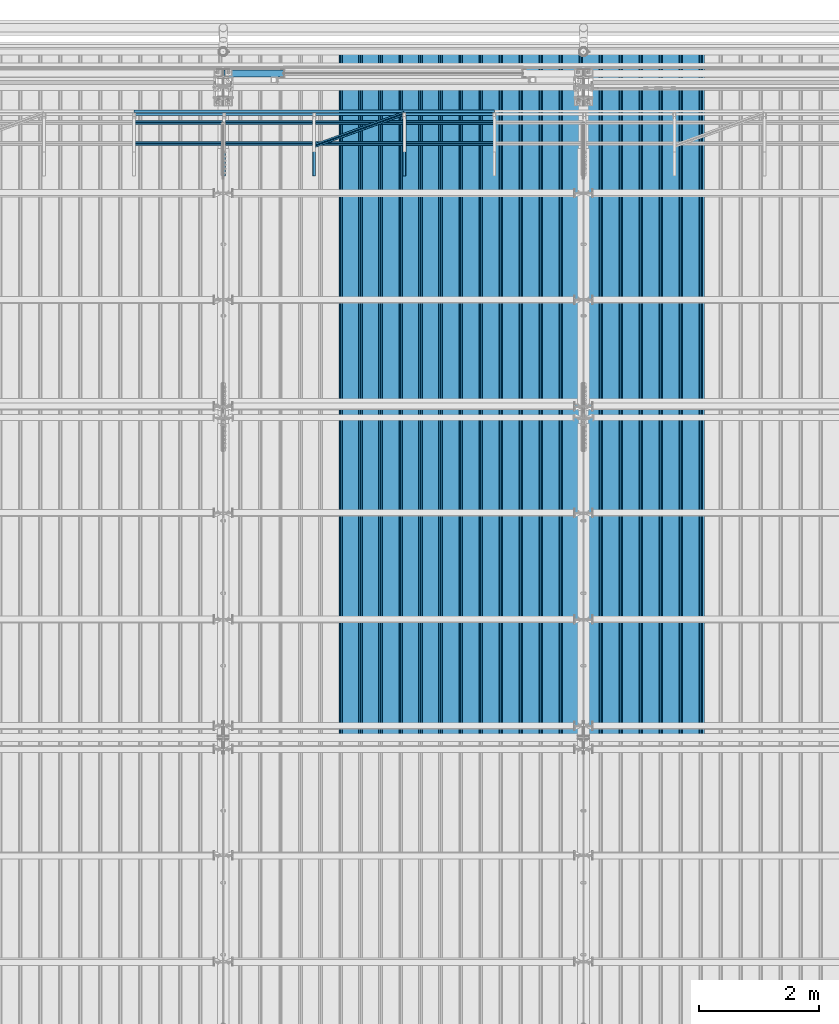
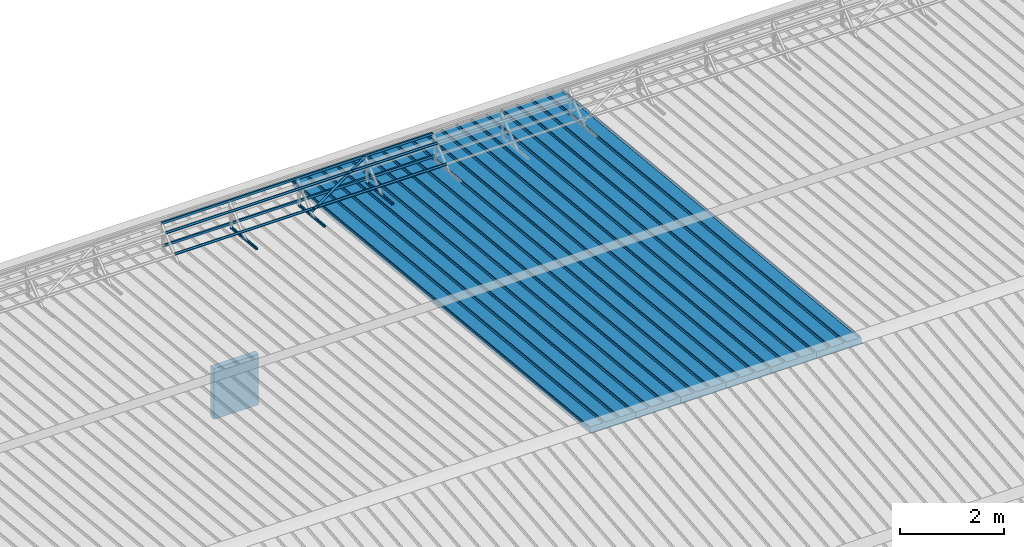
# One storey, part 57 of 709: 15 beams, 15 elements without a shape of their own.
"""IFC4 building model written with IfcOpenShell, lengths in millimetres."""

from ifc_helpers import new_model, si_unit, direction, frame, origin_with_axes, place, context, subcontext, project, spatial, line, indexed_curve, outline, extrude, material, element, aggregate, save


model = new_model("IFC4")

# Units and contexts
model_context = context("Model", 3, precision=0.2, world=origin_with_axes(), true_north=direction((0.0, 1.0)))
body_context = subcontext(model_context, "Body", "Model", "MODEL_VIEW")
ifc_project = project(units=[si_unit("LENGTHUNIT", "METRE", prefix="MILLI"), si_unit("AREAUNIT", "SQUARE_METRE"), si_unit("VOLUMEUNIT", "CUBIC_METRE"), si_unit("MASSUNIT", "GRAM", prefix="KILO"), si_unit("TIMEUNIT", "SECOND"), si_unit("PLANEANGLEUNIT", "RADIAN"), si_unit("SOLIDANGLEUNIT", "STERADIAN"), si_unit("THERMODYNAMICTEMPERATUREUNIT", "DEGREE_CELSIUS"), si_unit("LUMINOUSINTENSITYUNIT", "LUMEN")], contexts=[model_context])

# Site, building, storey
site_placement = place(None, origin_with_axes())
site = spatial("IfcSite", under=ifc_project, at=site_placement, CompositionType="ELEMENT")
building_placement = place(site_placement, origin_with_axes())
building = spatial("IfcBuilding", under=site, at=building_placement, Name="Undefined", CompositionType="ELEMENT")
storey_placement = place(building_placement, origin_with_axes())
storey = spatial("IfcBuildingStorey", under=building, at=storey_placement, Name="Undefined", CompositionType="ELEMENT", Elevation=0.0)

# Assembly, beam
assembly_1_placement = place(storey_placement, frame((23452.44, 11009.10459, 8419.96887), z_axis=(1.0, 0.0, 0.0), x_axis=(0.0, 0.9950371902, -0.099503719)))
assembly_1 = element("IfcElementAssembly", 1, at=assembly_1_placement, inside=storey)
ifc_material_1 = material(Name="Insulation", Category="Insulation")
beam_1_placement = place(assembly_1_placement, origin_with_axes())
beam_1 = element("IfcBeam", 2, at=beam_1_placement, material=ifc_material_1, ObjectType="P-99", context=body_context, shape_type="SolidModel", body=[
    extrude(outline(indexed_curve([(-509.8453, 89.5), (-490.1547, 89.5), (-471.67949, 57.5), (-471.67949, -88.5), (-436.67949, -88.5), (-436.67949, -91.5), (562.55841, -91.5), (562.55841, -89.5), (527.55841, -89.5), (527.55841, 57.5), (510.2379, 88.5), (489.7621, 88.5), (472.44159, 58.5), (196.71923, 58.5), (177.66667, 91.5), (155.66667, 91.5), (136.61411, 58.5), (-136.61411, 58.5), (-155.66667, 91.5), (-177.66667, 91.5), (-196.71923, 58.5), (-469.94744, 58.5), (-489.0, 91.5), (-511.0, 91.5), (-527.16581, 63.5), (-525.43376, 62.5)], segments=[line(1, 2, 3, 4, 5, 6, 7, 8, 9, 10, 11, 12, 13, 14, 15, 16, 17, 18, 19, 20, 21, 22, 23, 24, 25, 26, 1)])), frame((0.0, 0.0, 0.0), z_axis=(-1.0, 0.0, 0.0), x_axis=(0.0, 0.0, 1.0)), (0.0, 0.0, -1.0), 11459.0),
])
aggregate(assembly_1, [beam_1])

assembly_2_placement = place(storey_placement, frame((22452.44, 11009.10459, 8419.96887), z_axis=(1.0, 0.0, 0.0), x_axis=(0.0, 0.9950371902, -0.099503719)))
assembly_2 = element("IfcElementAssembly", 3, at=assembly_2_placement, inside=storey)
beam_2_placement = place(assembly_2_placement, origin_with_axes())
beam_2 = element("IfcBeam", 4, at=beam_2_placement, material=ifc_material_1, ObjectType="P-99", context=body_context, shape_type="SolidModel", body=[
    extrude(outline(indexed_curve([(-509.8453, 89.5), (-490.1547, 89.5), (-471.67949, 57.5), (-471.67949, -88.5), (-436.67949, -88.5), (-436.67949, -91.5), (562.55841, -91.5), (562.55841, -89.5), (527.55841, -89.5), (527.55841, 57.5), (510.2379, 88.5), (489.7621, 88.5), (472.44159, 58.5), (196.71923, 58.5), (177.66667, 91.5), (155.66667, 91.5), (136.61411, 58.5), (-136.61411, 58.5), (-155.66667, 91.5), (-177.66667, 91.5), (-196.71923, 58.5), (-469.94744, 58.5), (-489.0, 91.5), (-511.0, 91.5), (-527.16581, 63.5), (-525.43376, 62.5)], segments=[line(1, 2, 3, 4, 5, 6, 7, 8, 9, 10, 11, 12, 13, 14, 15, 16, 17, 18, 19, 20, 21, 22, 23, 24, 25, 26, 1)])), frame((0.0, 0.0, 0.0), z_axis=(-1.0, 0.0, 0.0), x_axis=(0.0, 0.0, 1.0)), (0.0, 0.0, -1.0), 11459.0),
])
aggregate(assembly_2, [beam_2])

assembly_3_placement = place(storey_placement, frame((21452.44, 11009.10459, 8419.96887), z_axis=(1.0, 0.0, 0.0), x_axis=(0.0, 0.9950371902, -0.099503719)))
assembly_3 = element("IfcElementAssembly", 5, at=assembly_3_placement, inside=storey)
beam_3_placement = place(assembly_3_placement, origin_with_axes())
beam_3 = element("IfcBeam", 6, at=beam_3_placement, material=ifc_material_1, ObjectType="P-99", context=body_context, shape_type="SolidModel", body=[
    extrude(outline(indexed_curve([(-509.8453, 89.5), (-490.1547, 89.5), (-471.67949, 57.5), (-471.67949, -88.5), (-436.67949, -88.5), (-436.67949, -91.5), (562.55841, -91.5), (562.55841, -89.5), (527.55841, -89.5), (527.55841, 57.5), (510.2379, 88.5), (489.7621, 88.5), (472.44159, 58.5), (196.71923, 58.5), (177.66667, 91.5), (155.66667, 91.5), (136.61411, 58.5), (-136.61411, 58.5), (-155.66667, 91.5), (-177.66667, 91.5), (-196.71923, 58.5), (-469.94744, 58.5), (-489.0, 91.5), (-511.0, 91.5), (-527.16581, 63.5), (-525.43376, 62.5)], segments=[line(1, 2, 3, 4, 5, 6, 7, 8, 9, 10, 11, 12, 13, 14, 15, 16, 17, 18, 19, 20, 21, 22, 23, 24, 25, 26, 1)])), frame((0.0, 0.0, 0.0), z_axis=(-1.0, 0.0, 0.0), x_axis=(0.0, 0.0, 1.0)), (0.0, 0.0, -1.0), 11459.0),
])
aggregate(assembly_3, [beam_3])

assembly_4_placement = place(storey_placement, frame((20452.44, 11009.10459, 8419.96887), z_axis=(1.0, 0.0, 0.0), x_axis=(0.0, 0.9950371902, -0.099503719)))
assembly_4 = element("IfcElementAssembly", 7, at=assembly_4_placement, inside=storey)
beam_4_placement = place(assembly_4_placement, origin_with_axes())
beam_4 = element("IfcBeam", 8, at=beam_4_placement, material=ifc_material_1, ObjectType="P-99", context=body_context, shape_type="SolidModel", body=[
    extrude(outline(indexed_curve([(-509.8453, 89.5), (-490.1547, 89.5), (-471.67949, 57.5), (-471.67949, -88.5), (-436.67949, -88.5), (-436.67949, -91.5), (562.55841, -91.5), (562.55841, -89.5), (527.55841, -89.5), (527.55841, 57.5), (510.2379, 88.5), (489.7621, 88.5), (472.44159, 58.5), (196.71923, 58.5), (177.66667, 91.5), (155.66667, 91.5), (136.61411, 58.5), (-136.61411, 58.5), (-155.66667, 91.5), (-177.66667, 91.5), (-196.71923, 58.5), (-469.94744, 58.5), (-489.0, 91.5), (-511.0, 91.5), (-527.16581, 63.5), (-525.43376, 62.5)], segments=[line(1, 2, 3, 4, 5, 6, 7, 8, 9, 10, 11, 12, 13, 14, 15, 16, 17, 18, 19, 20, 21, 22, 23, 24, 25, 26, 1)])), frame((0.0, 0.0, 0.0), z_axis=(-1.0, 0.0, 0.0), x_axis=(0.0, 0.0, 1.0)), (0.0, 0.0, -1.0), 11459.0),
])
aggregate(assembly_4, [beam_4])

assembly_5_placement = place(storey_placement, frame((19452.44, 11009.10459, 8419.96887), z_axis=(1.0, 0.0, 0.0), x_axis=(0.0, 0.9950371902, -0.099503719)))
assembly_5 = element("IfcElementAssembly", 9, at=assembly_5_placement, inside=storey)
beam_5_placement = place(assembly_5_placement, origin_with_axes())
beam_5 = element("IfcBeam", 10, at=beam_5_placement, material=ifc_material_1, ObjectType="P-99", context=body_context, shape_type="SolidModel", body=[
    extrude(outline(indexed_curve([(-509.8453, 89.5), (-490.1547, 89.5), (-471.67949, 57.5), (-471.67949, -88.5), (-436.67949, -88.5), (-436.67949, -91.5), (562.55841, -91.5), (562.55841, -89.5), (527.55841, -89.5), (527.55841, 57.5), (510.2379, 88.5), (489.7621, 88.5), (472.44159, 58.5), (196.71923, 58.5), (177.66667, 91.5), (155.66667, 91.5), (136.61411, 58.5), (-136.61411, 58.5), (-155.66667, 91.5), (-177.66667, 91.5), (-196.71923, 58.5), (-469.94744, 58.5), (-489.0, 91.5), (-511.0, 91.5), (-527.16581, 63.5), (-525.43376, 62.5)], segments=[line(1, 2, 3, 4, 5, 6, 7, 8, 9, 10, 11, 12, 13, 14, 15, 16, 17, 18, 19, 20, 21, 22, 23, 24, 25, 26, 1)])), frame((0.0, 0.0, 0.0), z_axis=(-1.0, 0.0, 0.0), x_axis=(0.0, 0.0, 1.0)), (0.0, 0.0, -1.0), 11459.0),
])
aggregate(assembly_5, [beam_5])

assembly_6_placement = place(storey_placement, frame((18452.44, 11009.10459, 8419.96887), z_axis=(1.0, 0.0, 0.0), x_axis=(0.0, 0.9950371902, -0.099503719)))
assembly_6 = element("IfcElementAssembly", 11, at=assembly_6_placement, inside=storey)
beam_6_placement = place(assembly_6_placement, origin_with_axes())
beam_6 = element("IfcBeam", 12, at=beam_6_placement, material=ifc_material_1, ObjectType="P-99", context=body_context, shape_type="SolidModel", body=[
    extrude(outline(indexed_curve([(-509.8453, 89.5), (-490.1547, 89.5), (-471.67949, 57.5), (-471.67949, -88.5), (-436.67949, -88.5), (-436.67949, -91.5), (562.55841, -91.5), (562.55841, -89.5), (527.55841, -89.5), (527.55841, 57.5), (510.2379, 88.5), (489.7621, 88.5), (472.44159, 58.5), (196.71923, 58.5), (177.66667, 91.5), (155.66667, 91.5), (136.61411, 58.5), (-136.61411, 58.5), (-155.66667, 91.5), (-177.66667, 91.5), (-196.71923, 58.5), (-469.94744, 58.5), (-489.0, 91.5), (-511.0, 91.5), (-527.16581, 63.5), (-525.43376, 62.5)], segments=[line(1, 2, 3, 4, 5, 6, 7, 8, 9, 10, 11, 12, 13, 14, 15, 16, 17, 18, 19, 20, 21, 22, 23, 24, 25, 26, 1)])), frame((0.0, 0.0, 0.0), z_axis=(-1.0, 0.0, 0.0), x_axis=(0.0, 0.0, 1.0)), (0.0, 0.0, -1.0), 11459.0),
])
aggregate(assembly_6, [beam_6])

assembly_7_placement = place(storey_placement, frame((19015.0, 21349.29926, 7565.33969), z_axis=(0.0, 0.099503719, 0.9950371902), x_axis=(0.0, -0.9950371902, 0.099503719)))
assembly_7 = element("IfcElementAssembly", 13, at=assembly_7_placement, inside=storey)
ifc_material_2 = material(Name="Steel_Undefined", Category="STEEL")
beam_7_placement = place(assembly_7_placement, origin_with_axes())
beam_7 = element("IfcBeam", 14, at=beam_7_placement, material=ifc_material_2, ObjectType="601", context=body_context, shape_type="SolidModel", body=[
    extrude(outline(indexed_curve([(-20.0, -25.0), (20.0, -25.0), (20.0, -22.5), (-17.5, -22.5), (-17.5, 22.5), (20.0, 22.5), (20.0, 25.0), (-20.0, 25.0)], segments=[line(1, 2, 3, 4, 5, 6, 7, 8, 1)])), frame((0.0, 0.0, 0.0), z_axis=(-1.0, 0.0, 0.0), x_axis=(0.0, 0.0, 1.0)), (0.0, 0.0, -1.0), 1000.0),
])
aggregate(assembly_7, [beam_7])

assembly_8_placement = place(storey_placement, frame((17515.0, 21349.29926, 7565.33969), z_axis=(0.0, 0.099503719, 0.9950371902), x_axis=(0.0, -0.9950371902, 0.099503719)))
assembly_8 = element("IfcElementAssembly", 15, at=assembly_8_placement, inside=storey)
beam_8_placement = place(assembly_8_placement, origin_with_axes())
beam_8 = element("IfcBeam", 16, at=beam_8_placement, material=ifc_material_2, ObjectType="601", context=body_context, shape_type="SolidModel", body=[
    extrude(outline(indexed_curve([(-20.0, -25.0), (20.0, -25.0), (20.0, -22.5), (-17.5, -22.5), (-17.5, 22.5), (20.0, 22.5), (20.0, 25.0), (-20.0, 25.0)], segments=[line(1, 2, 3, 4, 5, 6, 7, 8, 1)])), frame((0.0, 0.0, 0.0), z_axis=(-1.0, 0.0, 0.0), x_axis=(0.0, 0.0, 1.0)), (0.0, 0.0, -1.0), 1000.0),
])
aggregate(assembly_8, [beam_8])

assembly_9_placement = place(storey_placement, frame((16015.0, 21349.29926, 7565.33969), z_axis=(0.0, 0.099503719, 0.9950371902), x_axis=(0.0, -0.9950371902, 0.099503719)))
assembly_9 = element("IfcElementAssembly", 17, at=assembly_9_placement, inside=storey)
beam_9_placement = place(assembly_9_placement, origin_with_axes())
beam_9 = element("IfcBeam", 18, at=beam_9_placement, material=ifc_material_2, ObjectType="601", context=body_context, shape_type="SolidModel", body=[
    extrude(outline(indexed_curve([(-20.0, -25.0), (20.0, -25.0), (20.0, -22.5), (-17.5, -22.5), (-17.5, 22.5), (20.0, 22.5), (20.0, 25.0), (-20.0, 25.0)], segments=[line(1, 2, 3, 4, 5, 6, 7, 8, 1)])), frame((0.0, 0.0, 0.0), z_axis=(-1.0, 0.0, 0.0), x_axis=(0.0, 0.0, 1.0)), (0.0, 0.0, -1.0), 1000.0),
])
aggregate(assembly_9, [beam_9])

assembly_10_placement = place(storey_placement, frame((20515.0, 21426.91216, 8140.47118), z_axis=(0.0, 0.9950371902, -0.099503719), x_axis=(-1.0, 0.0, 0.0)))
assembly_10 = element("IfcElementAssembly", 19, at=assembly_10_placement, inside=storey)
beam_10_placement = place(assembly_10_placement, origin_with_axes())
beam_10 = element("IfcBeam", 20, at=beam_10_placement, material=ifc_material_2, ObjectType="606", context=body_context, shape_type="SolidModel", body=[
    extrude(outline(indexed_curve([(-20.0, -25.0), (20.0, -25.0), (20.0, -22.5), (-17.5, -22.5), (-17.5, 22.5), (20.0, 22.5), (20.0, 25.0), (-20.0, 25.0)], segments=[line(1, 2, 3, 4, 5, 6, 7, 8, 1)])), frame((0.0, 0.0, 0.0), z_axis=(-1.0, 0.0, 0.0), x_axis=(0.0, 0.0, 1.0)), (0.0, 0.0, -1.0), 6000.0),
])
aggregate(assembly_10, [beam_10])

assembly_11_placement = place(storey_placement, frame((20515.0, 21377.1603, 7642.95259), z_axis=(0.0, 0.9950371902, -0.099503719), x_axis=(-1.0, 0.0, 0.0)))
assembly_11 = element("IfcElementAssembly", 21, at=assembly_11_placement, inside=storey)
beam_11_placement = place(assembly_11_placement, origin_with_axes())
beam_11 = element("IfcBeam", 22, at=beam_11_placement, material=ifc_material_2, ObjectType="606", context=body_context, shape_type="SolidModel", body=[
    extrude(outline(indexed_curve([(-20.0, -25.0), (20.0, -25.0), (20.0, -22.5), (-17.5, -22.5), (-17.5, 22.5), (20.0, 22.5), (20.0, 25.0), (-20.0, 25.0)], segments=[line(1, 2, 3, 4, 5, 6, 7, 8, 1)])), frame((0.0, 0.0, 0.0), z_axis=(-1.0, 0.0, 0.0), x_axis=(0.0, 0.0, 1.0)), (0.0, 0.0, -1.0), 6000.0),
])
aggregate(assembly_11, [beam_11])

assembly_12_placement = place(storey_placement, frame((20515.0, 21239.5552, 8031.29285), z_axis=(0.0, -0.6332377902, 0.7739572992), x_axis=(-1.0, 0.0, 0.0)))
assembly_12 = element("IfcElementAssembly", 23, at=assembly_12_placement, inside=storey)
beam_12_placement = place(assembly_12_placement, origin_with_axes())
beam_12 = element("IfcBeam", 24, at=beam_12_placement, material=ifc_material_2, ObjectType="606", context=body_context, shape_type="SolidModel", body=[
    extrude(outline(indexed_curve([(-20.0, -25.0), (20.0, -25.0), (20.0, -22.5), (-17.5, -22.5), (-17.5, 22.5), (20.0, 22.5), (20.0, 25.0), (-20.0, 25.0)], segments=[line(1, 2, 3, 4, 5, 6, 7, 8, 1)])), frame((0.0, 0.0, 0.0), z_axis=(-1.0, 0.0, 0.0), x_axis=(0.0, 0.0, 1.0)), (0.0, 0.0, -1.0), 6000.0),
])
aggregate(assembly_12, [beam_12])

assembly_13_placement = place(storey_placement, frame((20515.0, 20892.41357, 7747.26788), z_axis=(0.0, -0.6332377902, 0.7739572992), x_axis=(-1.0, 0.0, 0.0)))
assembly_13 = element("IfcElementAssembly", 25, at=assembly_13_placement, inside=storey)
beam_13_placement = place(assembly_13_placement, origin_with_axes())
beam_13 = element("IfcBeam", 26, at=beam_13_placement, material=ifc_material_2, ObjectType="606", context=body_context, shape_type="SolidModel", body=[
    extrude(outline(indexed_curve([(-20.0, -25.0), (20.0, -25.0), (20.0, -22.5), (-17.5, -22.5), (-17.5, 22.5), (20.0, 22.5), (20.0, 25.0), (-20.0, 25.0)], segments=[line(1, 2, 3, 4, 5, 6, 7, 8, 1)])), frame((0.0, 0.0, 0.0), z_axis=(-1.0, 0.0, 0.0), x_axis=(0.0, 0.0, 1.0)), (0.0, 0.0, -1.0), 6000.0),
])
aggregate(assembly_13, [beam_13])

assembly_14_placement = place(storey_placement, frame((19015.0, 21394.34666, 8157.9404), z_axis=(0.0, -0.6332377902, 0.7739572992), x_axis=(-0.9061831398, -0.3272952929, -0.2677870579)))
assembly_14 = element("IfcElementAssembly", 27, at=assembly_14_placement, inside=storey)
beam_14_placement = place(assembly_14_placement, origin_with_axes())
beam_14 = element("IfcBeam", 28, at=beam_14_placement, material=ifc_material_2, ObjectType="605", context=body_context, shape_type="SolidModel", body=[
    extrude(outline(indexed_curve([(-20.0, -25.0), (20.0, -25.0), (20.0, -22.5), (-17.5, -22.5), (-17.5, 22.5), (20.0, 22.5), (20.0, 25.0), (-20.0, 25.0)], segments=[line(1, 2, 3, 4, 5, 6, 7, 8, 1)])), frame((0.0, 0.0, 0.0), z_axis=(-1.0, 0.0, 0.0), x_axis=(0.0, 0.0, 1.0)), (0.0, 0.0, -1.0), 1655.29454),
])
aggregate(assembly_14, [beam_14])

assembly_15_placement = place(storey_placement, frame((16010.0, 22060.0, 3275.0), z_axis=(0.0, 0.0, -1.0), x_axis=(1.0, 0.0, 0.0)))
assembly_15 = element("IfcElementAssembly", 29, at=assembly_15_placement, inside=storey)
beam_15_placement = place(assembly_15_placement, origin_with_axes())
beam_15 = element("IfcBeam", 30, at=beam_15_placement, material=ifc_material_1, ObjectType="P-110", context=body_context, shape_type="SolidModel", body=[
    extrude(outline(indexed_curve([(-595.0, -60.0), (595.0, -60.0), (595.0, 60.0), (-595.0, 60.0)], segments=[line(1, 2, 3, 4, 1)])), frame((0.0, 0.0, 0.0), z_axis=(-1.0, 0.0, 0.0), x_axis=(0.0, 0.0, 1.0)), (0.0, 0.0, -1.0), 990.0),
])
aggregate(assembly_15, [beam_15])

save(model, "model.ifc")
